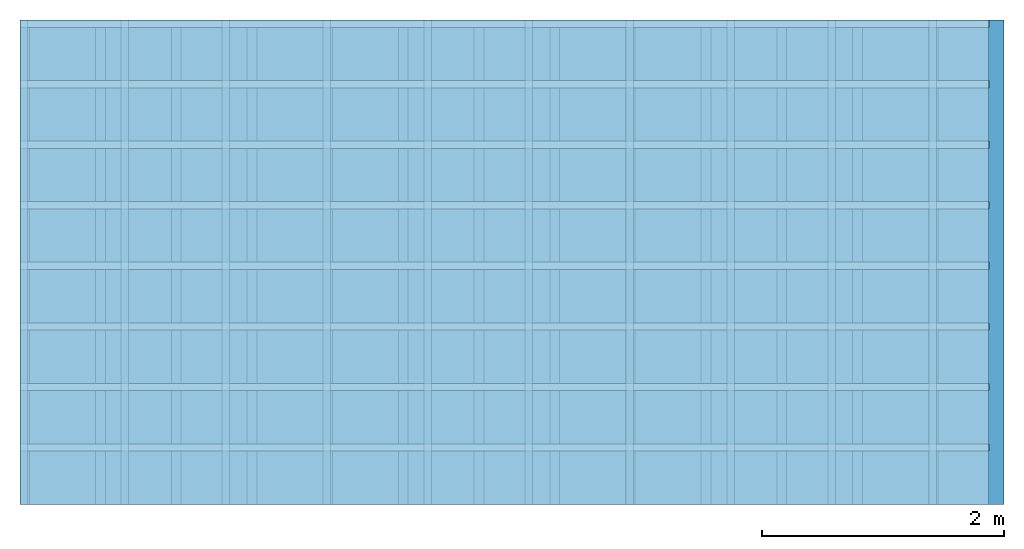
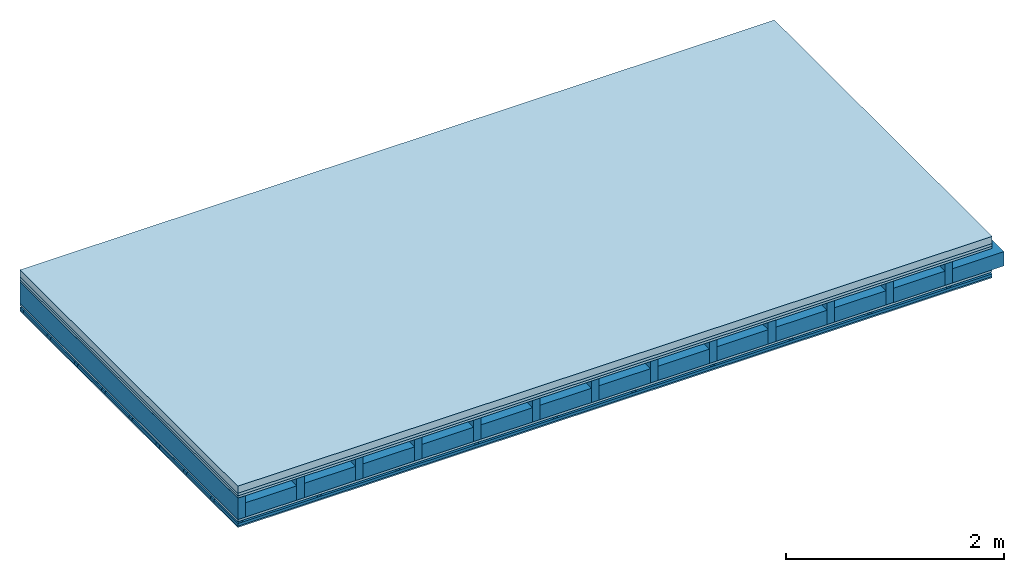
# One storey: 5 members, 5 plates, 1 element without a shape of its own.
"""IFC4 building model written with IfcOpenShell, lengths in metres."""

import ifcopenshell
import ifcopenshell.guid

model = None  # the IFC model being written
_history = None  # IfcOwnerHistory: only IFC2X3 demands one
_inside = {}  # id of a spatial element -> (the spatial element, [elements in it])
_under = {}  # id of a project, library or spatial element -> (it, [spatial elements below it])
_declared = {}  # id of a project -> (the project, [libraries it declares])
_typed = {}  # id of a type object -> (the type object, [elements of that type])
_made_of = {}  # id of a material, layer set ... -> (it, [elements and type objects made of it])


def new_model(schema):
    """Start an empty IFC model of exactly this schema.

    Asked for "IFC4X3", IfcOpenShell would pick the latest addendum, in which some entities
    have other attributes; the version numbers below select the first issue.
    IFC2X3 requires an IfcOwnerHistory on every rooted entity: one is made here for all.
    """
    global model, _history
    if schema == "IFC4X3":
        model = ifcopenshell.file(schema_version=(4, 3, 0, 0))
    else:
        model = ifcopenshell.file(schema=schema)
    _inside.clear()
    _under.clear()
    _declared.clear()
    _typed.clear()
    _made_of.clear()
    _history = None
    if model.schema == "IFC2X3":
        org = make("IfcOrganization", Name="unknown")
        user = make(
            "IfcPersonAndOrganization",
            ThePerson=make("IfcPerson", FamilyName="unknown"),
            TheOrganization=org,
        )
        app = make(
            "IfcApplication",
            ApplicationDeveloper=org,
            Version="unknown",
            ApplicationFullName="unknown",
            ApplicationIdentifier="unknown",
        )
        _history = make(
            "IfcOwnerHistory",
            OwningUser=user,
            OwningApplication=app,
            ChangeAction="ADDED",
            CreationDate=0,
        )
    return model


def make(cls, **values):
    """One entity of the class cls with the attributes given. An attribute that is None is left unset."""
    return model.create_entity(
        cls, **{name: value for name, value in values.items() if value is not None}
    )


def rooted(cls, **values):
    """An entity with a GlobalId (a new one), such as an element, a storey or a relation."""
    return make(cls, GlobalId=ifcopenshell.guid.new(), OwnerHistory=_history, **values)


def si_unit(unit_type, name, prefix=None):
    """IfcSIUnit, for example si_unit("LENGTHUNIT", "METRE", prefix="MILLI")."""
    return make("IfcSIUnit", UnitType=unit_type, Prefix=prefix, Name=name)


def derived_unit(unit_type, elements):
    """IfcDerivedUnit: a product of units, each with its exponent."""
    return make(
        "IfcDerivedUnit",
        Elements=[
            make("IfcDerivedUnitElement", Unit=unit, Exponent=power)
            for unit, power in elements
        ],
        UnitType=unit_type,
    )


def assignment(units):
    """IfcUnitAssignment: the units of a project."""
    return None if units is None else make("IfcUnitAssignment", Units=units)


def point(xyz):
    """IfcCartesianPoint."""
    return None if xyz is None else make("IfcCartesianPoint", Coordinates=xyz)


def direction(xyz):
    """IfcDirection."""
    return None if xyz is None else make("IfcDirection", DirectionRatios=xyz)


def frame(location, z_axis=None, x_axis=None):
    """IfcAxis2Placement3D, a coordinate frame: its origin and axes. An axis left out is left unset."""
    return make(
        "IfcAxis2Placement3D",
        Location=point(location),
        Axis=direction(z_axis),
        RefDirection=direction(x_axis),
    )


def frame_2d(location, x_axis=None):
    """IfcAxis2Placement2D, a coordinate frame in the plane: its origin and x axis."""
    return make(
        "IfcAxis2Placement2D", Location=point(location), RefDirection=direction(x_axis)
    )


def origin():
    """The frame at (0, 0, 0) with its axes left unset."""
    return frame((0.0, 0.0, 0.0))


def origin_with_axes():
    """The frame at (0, 0, 0) with the z axis (0, 0, 1) and the x axis (1, 0, 0) written out."""
    return frame((0.0, 0.0, 0.0), z_axis=(0.0, 0.0, 1.0), x_axis=(1.0, 0.0, 0.0))


def place(relative_to, where):
    """IfcLocalPlacement: puts the frame where relative to a parent placement (None: the world)."""
    return make(
        "IfcLocalPlacement", PlacementRelTo=relative_to, RelativePlacement=where
    )


def context(
    kind, dimensions, precision=None, world=None, true_north=None, identifier=None
):
    """IfcGeometricRepresentationContext, for example the 3D "Model" context."""
    return make(
        "IfcGeometricRepresentationContext",
        ContextIdentifier=identifier,
        ContextType=kind,
        CoordinateSpaceDimension=dimensions,
        Precision=precision,
        WorldCoordinateSystem=world,
        TrueNorth=true_north,
    )


def project(units=None, contexts=None):
    """IfcProject with its units and contexts."""
    return rooted(
        "IfcProject",
        Name="project",
        RepresentationContexts=contexts,
        UnitsInContext=assignment(units),
    )


def spatial(cls, under=None, at=None, **own):
    """A site, building, storey or space (cls), placed at a placement, below another one or the project."""
    s = rooted(cls, ObjectPlacement=at, **own)
    if under is not None:
        _under.setdefault(under.id(), (under, []))[1].append(s)
    return s


def polyline(points):
    """IfcPolyline through the points."""
    return make("IfcPolyline", Points=[point(p) for p in points])


def profile(cls, at=None, kind="AREA", **sizes):
    """A parametric profile (cls). Its sizes go by their IFC names, for example OverallWidth=200.0."""
    return make(cls, ProfileType=kind, Position=at, **sizes)


def rectangle(**sizes):
    """IfcRectangleProfileDef."""
    return profile("IfcRectangleProfileDef", **sizes)


def outline(outer, holes=None, kind="AREA"):
    """IfcArbitraryClosedProfileDef: a profile drawn as a closed curve; with holes, ...WithVoids."""
    if holes is None:
        return make("IfcArbitraryClosedProfileDef", ProfileType=kind, OuterCurve=outer)
    return make(
        "IfcArbitraryProfileDefWithVoids",
        ProfileType=kind,
        OuterCurve=outer,
        InnerCurves=holes,
    )


def extrude(swept, where, along, depth):
    """IfcExtrudedAreaSolid: the profile swept, set in the frame where, extruded along a direction by depth."""
    return make(
        "IfcExtrudedAreaSolid",
        SweptArea=swept,
        Position=where,
        ExtrudedDirection=direction(along),
        Depth=depth,
    )


def shape(context_of_items, identifier, shape_type, items):
    """IfcShapeRepresentation: the items that make up one representation, for example the "Body"."""
    return make(
        "IfcShapeRepresentation",
        ContextOfItems=context_of_items,
        RepresentationIdentifier=identifier,
        RepresentationType=shape_type,
        Items=items,
    )


def material(Name=None, Category=None):
    """IfcMaterial."""
    return make("IfcMaterial", Name=Name, Category=Category)


def layer(
    of_material, thickness, ventilated=None, Name=None, Category=None, Priority=None
):
    """IfcMaterialLayer: one layer of a wall or slab, of a material (None: an air gap)."""
    return make(
        "IfcMaterialLayer",
        Material=of_material,
        LayerThickness=thickness,
        IsVentilated=ventilated,
        Name=Name,
        Category=Category,
        Priority=Priority,
    )


def layer_set(layers, Name=None):
    """IfcMaterialLayerSet."""
    return make("IfcMaterialLayerSet", MaterialLayers=layers, LayerSetName=Name)


def made_of(thing, what):
    """Note that an element or type object is made of a material, layer set ...; save() writes the relation."""
    if what is not None:
        _made_of.setdefault(what.id(), (what, []))[1].append(thing)
    return thing


def type_object(cls, material=None, **own):
    """A type object (cls), such as IfcWallType, which elements share."""
    return made_of(rooted(cls, **own), material)


def element(
    cls,
    number,
    at=None,
    inside=None,
    cuts=None,
    type_object=None,
    material=None,
    context=None,
    identifier="Body",
    shape_type=None,
    held_by="IfcProductDefinitionShape",
    body=None,
    shapes=None,
    **own,
):
    """One element of the class cls, such as IfcWall. Its Tag is "e" and its number.

    at: its placement. inside: the storey or other place that contains it. cuts: it is an
    opening in that element (IfcRelVoidsElement). A single representation is given by context,
    identifier, shape_type and body (its items); several are given by shapes. held_by: the class
    of the entity that holds the representations. save() writes the other relations.
    """
    e = rooted(cls, Tag="e%d" % number, ObjectPlacement=at, **own)
    if body is not None:
        shapes = [shape(context, identifier, shape_type, body)]
    if shapes is not None:
        e.Representation = make(held_by, Representations=shapes)
    if inside is not None:
        _inside.setdefault(inside.id(), (inside, []))[1].append(e)
    if cuts is not None:
        rooted(
            "IfcRelVoidsElement", RelatingBuildingElement=cuts, RelatedOpeningElement=e
        )
    if type_object is not None:
        _typed.setdefault(type_object.id(), (type_object, []))[1].append(e)
    return made_of(e, material)


def aggregate(whole, parts):
    """IfcRelAggregates: a whole, such as a stair, and the parts it consists of."""
    return rooted("IfcRelAggregates", RelatingObject=whole, RelatedObjects=parts)


def save(model, path):
    """Write the relations noted so far, then the file.

    IfcRelAggregates (storeys below a building ...), IfcRelContainedInSpatialStructure (elements
    in a storey), IfcRelDefinesByType, IfcRelAssociatesMaterial and IfcRelDeclares: one each for
    every whole, place, type object, material and project.
    """
    for whole, parts in _under.values():
        aggregate(whole, parts)
    for where, things in _inside.values():
        rooted(
            "IfcRelContainedInSpatialStructure",
            RelatedElements=things,
            RelatingStructure=where,
        )
    for kind, things in _typed.values():
        rooted("IfcRelDefinesByType", RelatedObjects=things, RelatingType=kind)
    for what, things in _made_of.values():
        rooted("IfcRelAssociatesMaterial", RelatedObjects=things, RelatingMaterial=what)
    for by, libraries in _declared.values():
        rooted("IfcRelDeclares", RelatingContext=by, RelatedDefinitions=libraries)
    model.write(path)


model = new_model("IFC4")

# Units and contexts
plan_context = context("Plan", 3, precision=1e-05, world=origin(), true_north=direction((0.0, 1.0)))
model_context = context("Model", 3, precision=1e-05, world=origin(), true_north=direction((0.0, 1.0)))
ifc_project = project(units=[si_unit("LENGTHUNIT", "METRE"), derived_unit("SOUNDPRESSUREUNIT", [(si_unit("PRESSUREUNIT", "PASCAL", prefix="MICRO"), 0)]), si_unit("ENERGYUNIT", "JOULE", prefix="MEGA"), si_unit("MASSUNIT", "GRAM", prefix="KILO"), derived_unit("THERMALTRANSMITTANCEUNIT", [(si_unit("POWERUNIT", "WATT"), 1), (si_unit("AREAUNIT", "SQUARE_METRE"), -1), (si_unit("THERMODYNAMICTEMPERATUREUNIT", "KELVIN"), -1)]), derived_unit("AREADENSITYUNIT", [(si_unit("MASSUNIT", "GRAM", prefix="KILO"), 1), (si_unit("AREAUNIT", "SQUARE_METRE"), -1)]), derived_unit("USERDEFINED", [(si_unit("ENERGYUNIT", "JOULE", prefix="MEGA"), 1), (si_unit("AREAUNIT", "SQUARE_METRE"), -1)])], contexts=[plan_context, model_context])

# Site, building, storey
site = spatial("IfcSite", under=ifc_project)
building_placement = place(None, origin())
building = spatial("IfcBuilding", under=site, at=building_placement)
storey_placement = place(building_placement, origin())
storey = spatial("IfcBuildingStorey", under=building, at=storey_placement)

# Slab, members, plates
ifc_material_1 = material(Name="Cement screed", Category="04.006")
ifc_layer_1 = layer(ifc_material_1, 0.08, Name="On-material")
ifc_material_2 = material()
ifc_layer_2 = layer(ifc_material_2, 0.03, Name="Impact sound insulation")
ifc_material_3 = material(Category="07.001")
ifc_layer_3 = layer(ifc_material_3, 0.025, Name="Sub-floor")
ifc_material_4 = material(Name="Rigid, of the art")
ifc_layer_4 = layer(ifc_material_4, 0.0, Name="Bond")
ifc_layer_5 = layer(None, 0.24, Name="Supporting structure")
ifc_layer_6 = layer(ifc_material_4, 0.0, Name="Bond")
ifc_layer_7 = layer(ifc_material_3, 0.025, Name="Lower layer 1")
ifc_layer_8 = layer(None, 0.02, Name="Coupling")
ifc_layer_9 = layer(None, 0.03, Name="Battens / profiles")
ifc_material_5 = material(Category="03.007")
ifc_layer_10 = layer(ifc_material_5, 0.015, Name="Ceiling covering 1st layer")
ifc_material_6 = material(Name="Glued joints")
ifc_layer_11 = layer(ifc_material_6, 0.0, Name="Surface / treatment")
ifc_layer_set = layer_set([ifc_layer_1, ifc_layer_2, ifc_layer_3, ifc_layer_4, ifc_layer_5, ifc_layer_6, ifc_layer_7, ifc_layer_8, ifc_layer_9, ifc_layer_10, ifc_layer_11])
slab_type = type_object("IfcSlabType", Name="A0318", PredefinedType="NOTDEFINED", material=ifc_layer_set)
slab_placement = place(None, frame((0.0, 0.0, 0.0), z_axis=(0.0, 0.0, -1.0), x_axis=(1.0, 0.0, 0.0)))
slab = element("IfcSlab", 1, at=slab_placement, inside=storey, type_object=slab_type, material=ifc_layer_set, Name="Slab #1")
ifc_material_7 = material()
member_1_placement = place(slab_placement, origin())
member_1 = element("IfcMember", 2, at=member_1_placement, material=ifc_material_7, Name="Supporting structure", context=plan_context, shape_type="SweptSolid", body=[
    extrude(rectangle(XDim=0.08, YDim=0.24, at=frame_2d((0.04, 0.12), x_axis=(1.0, 0.0))), frame((0.0, 4.0, 0.135), z_axis=(0.0, -1.0, 0.0), x_axis=(1.0, 0.0, 0.0)), (0.0, 0.0, 1.0), 4.0),
    extrude(rectangle(XDim=0.08, YDim=0.24, at=frame_2d((0.04, 0.12), x_axis=(1.0, 0.0))), frame((0.625, 4.0, 0.135), z_axis=(0.0, -1.0, 0.0), x_axis=(1.0, 0.0, 0.0)), (0.0, 0.0, 1.0), 4.0),
    extrude(rectangle(XDim=0.08, YDim=0.24, at=frame_2d((0.04, 0.12), x_axis=(1.0, 0.0))), frame((1.25, 4.0, 0.135), z_axis=(0.0, -1.0, 0.0), x_axis=(1.0, 0.0, 0.0)), (0.0, 0.0, 1.0), 4.0),
    extrude(rectangle(XDim=0.08, YDim=0.24, at=frame_2d((0.04, 0.12), x_axis=(1.0, 0.0))), frame((1.875, 4.0, 0.135), z_axis=(0.0, -1.0, 0.0), x_axis=(1.0, 0.0, 0.0)), (0.0, 0.0, 1.0), 4.0),
    extrude(rectangle(XDim=0.08, YDim=0.24, at=frame_2d((0.04, 0.12), x_axis=(1.0, 0.0))), frame((2.5, 4.0, 0.135), z_axis=(0.0, -1.0, 0.0), x_axis=(1.0, 0.0, 0.0)), (0.0, 0.0, 1.0), 4.0),
    extrude(rectangle(XDim=0.08, YDim=0.24, at=frame_2d((0.04, 0.12), x_axis=(1.0, 0.0))), frame((3.125, 4.0, 0.135), z_axis=(0.0, -1.0, 0.0), x_axis=(1.0, 0.0, 0.0)), (0.0, 0.0, 1.0), 4.0),
    extrude(rectangle(XDim=0.08, YDim=0.24, at=frame_2d((0.04, 0.12), x_axis=(1.0, 0.0))), frame((3.75, 4.0, 0.135), z_axis=(0.0, -1.0, 0.0), x_axis=(1.0, 0.0, 0.0)), (0.0, 0.0, 1.0), 4.0),
    extrude(rectangle(XDim=0.08, YDim=0.24, at=frame_2d((0.04, 0.12), x_axis=(1.0, 0.0))), frame((4.375, 4.0, 0.135), z_axis=(0.0, -1.0, 0.0), x_axis=(1.0, 0.0, 0.0)), (0.0, 0.0, 1.0), 4.0),
    extrude(rectangle(XDim=0.08, YDim=0.24, at=frame_2d((0.04, 0.12), x_axis=(1.0, 0.0))), frame((5.0, 4.0, 0.135), z_axis=(0.0, -1.0, 0.0), x_axis=(1.0, 0.0, 0.0)), (0.0, 0.0, 1.0), 4.0),
    extrude(rectangle(XDim=0.08, YDim=0.24, at=frame_2d((0.04, 0.12), x_axis=(1.0, 0.0))), frame((5.625, 4.0, 0.135), z_axis=(0.0, -1.0, 0.0), x_axis=(1.0, 0.0, 0.0)), (0.0, 0.0, 1.0), 4.0),
    extrude(rectangle(XDim=0.08, YDim=0.24, at=frame_2d((0.04, 0.12), x_axis=(1.0, 0.0))), frame((6.25, 4.0, 0.135), z_axis=(0.0, -1.0, 0.0), x_axis=(1.0, 0.0, 0.0)), (0.0, 0.0, 1.0), 4.0),
    extrude(rectangle(XDim=0.08, YDim=0.24, at=frame_2d((0.04, 0.12), x_axis=(1.0, 0.0))), frame((6.875, 4.0, 0.135), z_axis=(0.0, -1.0, 0.0), x_axis=(1.0, 0.0, 0.0)), (0.0, 0.0, 1.0), 4.0),
    extrude(rectangle(XDim=0.08, YDim=0.24, at=frame_2d((0.04, 0.12), x_axis=(1.0, 0.0))), frame((7.5, 4.0, 0.135), z_axis=(0.0, -1.0, 0.0), x_axis=(1.0, 0.0, 0.0)), (0.0, 0.0, 1.0), 4.0),
])
ifc_material_8 = material()
member_2_placement = place(slab_placement, origin())
member_2 = element("IfcMember", 3, at=member_2_placement, material=ifc_material_8, Name="Cavity", context=plan_context, shape_type="SweptSolid", body=[
    extrude(rectangle(XDim=0.545, YDim=0.16, at=frame_2d((0.2725, 0.08), x_axis=(1.0, 0.0))), frame((0.08, 4.0, 0.215), z_axis=(0.0, -1.0, 0.0), x_axis=(1.0, 0.0, 0.0)), (0.0, 0.0, 1.0), 4.0),
    extrude(rectangle(XDim=0.545, YDim=0.16, at=frame_2d((0.2725, 0.08), x_axis=(1.0, 0.0))), frame((0.705, 4.0, 0.215), z_axis=(0.0, -1.0, 0.0), x_axis=(1.0, 0.0, 0.0)), (0.0, 0.0, 1.0), 4.0),
    extrude(rectangle(XDim=0.545, YDim=0.16, at=frame_2d((0.2725, 0.08), x_axis=(1.0, 0.0))), frame((1.33, 4.0, 0.215), z_axis=(0.0, -1.0, 0.0), x_axis=(1.0, 0.0, 0.0)), (0.0, 0.0, 1.0), 4.0),
    extrude(rectangle(XDim=0.545, YDim=0.16, at=frame_2d((0.2725, 0.08), x_axis=(1.0, 0.0))), frame((1.955, 4.0, 0.215), z_axis=(0.0, -1.0, 0.0), x_axis=(1.0, 0.0, 0.0)), (0.0, 0.0, 1.0), 4.0),
    extrude(rectangle(XDim=0.545, YDim=0.16, at=frame_2d((0.2725, 0.08), x_axis=(1.0, 0.0))), frame((2.58, 4.0, 0.215), z_axis=(0.0, -1.0, 0.0), x_axis=(1.0, 0.0, 0.0)), (0.0, 0.0, 1.0), 4.0),
    extrude(rectangle(XDim=0.545, YDim=0.16, at=frame_2d((0.2725, 0.08), x_axis=(1.0, 0.0))), frame((3.205, 4.0, 0.215), z_axis=(0.0, -1.0, 0.0), x_axis=(1.0, 0.0, 0.0)), (0.0, 0.0, 1.0), 4.0),
    extrude(rectangle(XDim=0.545, YDim=0.16, at=frame_2d((0.2725, 0.08), x_axis=(1.0, 0.0))), frame((3.83, 4.0, 0.215), z_axis=(0.0, -1.0, 0.0), x_axis=(1.0, 0.0, 0.0)), (0.0, 0.0, 1.0), 4.0),
    extrude(rectangle(XDim=0.545, YDim=0.16, at=frame_2d((0.2725, 0.08), x_axis=(1.0, 0.0))), frame((4.455, 4.0, 0.215), z_axis=(0.0, -1.0, 0.0), x_axis=(1.0, 0.0, 0.0)), (0.0, 0.0, 1.0), 4.0),
    extrude(rectangle(XDim=0.545, YDim=0.16, at=frame_2d((0.2725, 0.08), x_axis=(1.0, 0.0))), frame((5.08, 4.0, 0.215), z_axis=(0.0, -1.0, 0.0), x_axis=(1.0, 0.0, 0.0)), (0.0, 0.0, 1.0), 4.0),
    extrude(rectangle(XDim=0.545, YDim=0.16, at=frame_2d((0.2725, 0.08), x_axis=(1.0, 0.0))), frame((5.705, 4.0, 0.215), z_axis=(0.0, -1.0, 0.0), x_axis=(1.0, 0.0, 0.0)), (0.0, 0.0, 1.0), 4.0),
    extrude(rectangle(XDim=0.545, YDim=0.16, at=frame_2d((0.2725, 0.08), x_axis=(1.0, 0.0))), frame((6.33, 4.0, 0.215), z_axis=(0.0, -1.0, 0.0), x_axis=(1.0, 0.0, 0.0)), (0.0, 0.0, 1.0), 4.0),
    extrude(rectangle(XDim=0.545, YDim=0.16, at=frame_2d((0.2725, 0.08), x_axis=(1.0, 0.0))), frame((6.955, 4.0, 0.215), z_axis=(0.0, -1.0, 0.0), x_axis=(1.0, 0.0, 0.0)), (0.0, 0.0, 1.0), 4.0),
    extrude(rectangle(XDim=0.545, YDim=0.16, at=frame_2d((0.2725, 0.08), x_axis=(1.0, 0.0))), frame((7.58, 4.0, 0.215), z_axis=(0.0, -1.0, 0.0), x_axis=(1.0, 0.0, 0.0)), (0.0, 0.0, 1.0), 4.0),
])
ifc_material_9 = material()
member_3_placement = place(slab_placement, origin())
member_3 = element("IfcMember", 4, at=member_3_placement, material=ifc_material_9, Name="Coupling", context=plan_context, shape_type="SweptSolid", body=[
    extrude(outline(polyline([(0.0, 0.0), (0.06, 0.0), (0.04, 0.02), (0.02, 0.02), (0.0, 0.0)])), frame((0.0, 4.0, 0.4), z_axis=(0.0, -1.0, 0.0), x_axis=(1.0, 0.0, 0.0)), (0.0, 0.0, 1.0), 4.0),
    extrude(outline(polyline([(0.0, 0.0), (0.06, 0.0), (0.04, 0.02), (0.02, 0.02), (0.0, 0.0)])), frame((0.834, 4.0, 0.4), z_axis=(0.0, -1.0, 0.0), x_axis=(1.0, 0.0, 0.0)), (0.0, 0.0, 1.0), 4.0),
    extrude(outline(polyline([(0.0, 0.0), (0.06, 0.0), (0.04, 0.02), (0.02, 0.02), (0.0, 0.0)])), frame((1.668, 4.0, 0.4), z_axis=(0.0, -1.0, 0.0), x_axis=(1.0, 0.0, 0.0)), (0.0, 0.0, 1.0), 4.0),
    extrude(outline(polyline([(0.0, 0.0), (0.06, 0.0), (0.04, 0.02), (0.02, 0.02), (0.0, 0.0)])), frame((2.502, 4.0, 0.4), z_axis=(0.0, -1.0, 0.0), x_axis=(1.0, 0.0, 0.0)), (0.0, 0.0, 1.0), 4.0),
    extrude(outline(polyline([(0.0, 0.0), (0.06, 0.0), (0.04, 0.02), (0.02, 0.02), (0.0, 0.0)])), frame((3.336, 4.0, 0.4), z_axis=(0.0, -1.0, 0.0), x_axis=(1.0, 0.0, 0.0)), (0.0, 0.0, 1.0), 4.0),
    extrude(outline(polyline([(0.0, 0.0), (0.06, 0.0), (0.04, 0.02), (0.02, 0.02), (0.0, 0.0)])), frame((4.17, 4.0, 0.4), z_axis=(0.0, -1.0, 0.0), x_axis=(1.0, 0.0, 0.0)), (0.0, 0.0, 1.0), 4.0),
    extrude(outline(polyline([(0.0, 0.0), (0.06, 0.0), (0.04, 0.02), (0.02, 0.02), (0.0, 0.0)])), frame((5.004, 4.0, 0.4), z_axis=(0.0, -1.0, 0.0), x_axis=(1.0, 0.0, 0.0)), (0.0, 0.0, 1.0), 4.0),
    extrude(outline(polyline([(0.0, 0.0), (0.06, 0.0), (0.04, 0.02), (0.02, 0.02), (0.0, 0.0)])), frame((5.838, 4.0, 0.4), z_axis=(0.0, -1.0, 0.0), x_axis=(1.0, 0.0, 0.0)), (0.0, 0.0, 1.0), 4.0),
    extrude(outline(polyline([(0.0, 0.0), (0.06, 0.0), (0.04, 0.02), (0.02, 0.02), (0.0, 0.0)])), frame((6.672, 4.0, 0.4), z_axis=(0.0, -1.0, 0.0), x_axis=(1.0, 0.0, 0.0)), (0.0, 0.0, 1.0), 4.0),
    extrude(outline(polyline([(0.0, 0.0), (0.06, 0.0), (0.04, 0.02), (0.02, 0.02), (0.0, 0.0)])), frame((7.506, 4.0, 0.4), z_axis=(0.0, -1.0, 0.0), x_axis=(1.0, 0.0, 0.0)), (0.0, 0.0, 1.0), 4.0),
])
ifc_material_10 = material()
member_4_placement = place(slab_placement, origin())
member_4 = element("IfcMember", 5, at=member_4_placement, material=ifc_material_10, Name="Battens / profiles", context=plan_context, shape_type="SweptSolid", body=[
    extrude(rectangle(XDim=0.06, YDim=0.03, at=frame_2d((0.03, 0.015), x_axis=(1.0, 0.0))), frame((0.0, 0.0, 0.42), z_axis=(1.0, 0.0, 0.0), x_axis=(0.0, 1.0, 0.0)), (0.0, 0.0, 1.0), 8.0),
    extrude(rectangle(XDim=0.06, YDim=0.03, at=frame_2d((0.03, 0.015), x_axis=(1.0, 0.0))), frame((0.0, 0.5, 0.42), z_axis=(1.0, 0.0, 0.0), x_axis=(0.0, 1.0, 0.0)), (0.0, 0.0, 1.0), 8.0),
    extrude(rectangle(XDim=0.06, YDim=0.03, at=frame_2d((0.03, 0.015), x_axis=(1.0, 0.0))), frame((0.0, 1.0, 0.42), z_axis=(1.0, 0.0, 0.0), x_axis=(0.0, 1.0, 0.0)), (0.0, 0.0, 1.0), 8.0),
    extrude(rectangle(XDim=0.06, YDim=0.03, at=frame_2d((0.03, 0.015), x_axis=(1.0, 0.0))), frame((0.0, 1.5, 0.42), z_axis=(1.0, 0.0, 0.0), x_axis=(0.0, 1.0, 0.0)), (0.0, 0.0, 1.0), 8.0),
    extrude(rectangle(XDim=0.06, YDim=0.03, at=frame_2d((0.03, 0.015), x_axis=(1.0, 0.0))), frame((0.0, 2.0, 0.42), z_axis=(1.0, 0.0, 0.0), x_axis=(0.0, 1.0, 0.0)), (0.0, 0.0, 1.0), 8.0),
    extrude(rectangle(XDim=0.06, YDim=0.03, at=frame_2d((0.03, 0.015), x_axis=(1.0, 0.0))), frame((0.0, 2.5, 0.42), z_axis=(1.0, 0.0, 0.0), x_axis=(0.0, 1.0, 0.0)), (0.0, 0.0, 1.0), 8.0),
    extrude(rectangle(XDim=0.06, YDim=0.03, at=frame_2d((0.03, 0.015), x_axis=(1.0, 0.0))), frame((0.0, 3.0, 0.42), z_axis=(1.0, 0.0, 0.0), x_axis=(0.0, 1.0, 0.0)), (0.0, 0.0, 1.0), 8.0),
    extrude(rectangle(XDim=0.06, YDim=0.03, at=frame_2d((0.03, 0.015), x_axis=(1.0, 0.0))), frame((0.0, 3.5, 0.42), z_axis=(1.0, 0.0, 0.0), x_axis=(0.0, 1.0, 0.0)), (0.0, 0.0, 1.0), 8.0),
])
member_5_placement = place(slab_placement, origin())
member_5 = element("IfcMember", 6, at=member_5_placement, material=ifc_material_8, Name="Cavity", context=plan_context, shape_type="SweptSolid", body=[
    extrude(rectangle(XDim=0.44, YDim=0.03, at=frame_2d((0.22, 0.015), x_axis=(1.0, 0.0))), frame((0.0, 0.06, 0.42), z_axis=(1.0, 0.0, 0.0), x_axis=(0.0, 1.0, 0.0)), (0.0, 0.0, 1.0), 8.0),
    extrude(rectangle(XDim=0.44, YDim=0.03, at=frame_2d((0.22, 0.015), x_axis=(1.0, 0.0))), frame((0.0, 0.56, 0.42), z_axis=(1.0, 0.0, 0.0), x_axis=(0.0, 1.0, 0.0)), (0.0, 0.0, 1.0), 8.0),
    extrude(rectangle(XDim=0.44, YDim=0.03, at=frame_2d((0.22, 0.015), x_axis=(1.0, 0.0))), frame((0.0, 1.06, 0.42), z_axis=(1.0, 0.0, 0.0), x_axis=(0.0, 1.0, 0.0)), (0.0, 0.0, 1.0), 8.0),
    extrude(rectangle(XDim=0.44, YDim=0.03, at=frame_2d((0.22, 0.015), x_axis=(1.0, 0.0))), frame((0.0, 1.56, 0.42), z_axis=(1.0, 0.0, 0.0), x_axis=(0.0, 1.0, 0.0)), (0.0, 0.0, 1.0), 8.0),
    extrude(rectangle(XDim=0.44, YDim=0.03, at=frame_2d((0.22, 0.015), x_axis=(1.0, 0.0))), frame((0.0, 2.06, 0.42), z_axis=(1.0, 0.0, 0.0), x_axis=(0.0, 1.0, 0.0)), (0.0, 0.0, 1.0), 8.0),
    extrude(rectangle(XDim=0.44, YDim=0.03, at=frame_2d((0.22, 0.015), x_axis=(1.0, 0.0))), frame((0.0, 2.56, 0.42), z_axis=(1.0, 0.0, 0.0), x_axis=(0.0, 1.0, 0.0)), (0.0, 0.0, 1.0), 8.0),
    extrude(rectangle(XDim=0.44, YDim=0.03, at=frame_2d((0.22, 0.015), x_axis=(1.0, 0.0))), frame((0.0, 3.06, 0.42), z_axis=(1.0, 0.0, 0.0), x_axis=(0.0, 1.0, 0.0)), (0.0, 0.0, 1.0), 8.0),
    extrude(rectangle(XDim=0.44, YDim=0.03, at=frame_2d((0.22, 0.015), x_axis=(1.0, 0.0))), frame((0.0, 3.56, 0.42), z_axis=(1.0, 0.0, 0.0), x_axis=(0.0, 1.0, 0.0)), (0.0, 0.0, 1.0), 8.0),
])
plate_1_placement = place(slab_placement, origin())
plate_1 = element("IfcPlate", 7, at=plate_1_placement, material=ifc_material_1, Name="On-material", context=plan_context, shape_type="SweptSolid", body=[
    extrude(rectangle(XDim=8.0, YDim=4.0, at=frame_2d((4.0, 2.0), x_axis=(1.0, 0.0))), origin_with_axes(), (0.0, 0.0, 1.0), 0.08),
])
plate_2_placement = place(slab_placement, origin())
plate_2 = element("IfcPlate", 8, at=plate_2_placement, material=ifc_material_2, Name="Impact sound insulation", context=plan_context, shape_type="SweptSolid", body=[
    extrude(rectangle(XDim=8.0, YDim=4.0, at=frame_2d((4.0, 2.0), x_axis=(1.0, 0.0))), frame((0.0, 0.0, 0.08), z_axis=(0.0, 0.0, 1.0), x_axis=(1.0, 0.0, 0.0)), (0.0, 0.0, 1.0), 0.03),
])
plate_3_placement = place(slab_placement, origin())
plate_3 = element("IfcPlate", 9, at=plate_3_placement, material=ifc_material_3, Name="Sub-floor", context=plan_context, shape_type="SweptSolid", body=[
    extrude(rectangle(XDim=8.0, YDim=4.0, at=frame_2d((4.0, 2.0), x_axis=(1.0, 0.0))), frame((0.0, 0.0, 0.11), z_axis=(0.0, 0.0, 1.0), x_axis=(1.0, 0.0, 0.0)), (0.0, 0.0, 1.0), 0.025),
])
plate_4_placement = place(slab_placement, origin())
plate_4 = element("IfcPlate", 10, at=plate_4_placement, material=ifc_material_3, Name="Lower layer 1", context=plan_context, shape_type="SweptSolid", body=[
    extrude(rectangle(XDim=8.0, YDim=4.0, at=frame_2d((4.0, 2.0), x_axis=(1.0, 0.0))), frame((0.0, 0.0, 0.375), z_axis=(0.0, 0.0, 1.0), x_axis=(1.0, 0.0, 0.0)), (0.0, 0.0, 1.0), 0.025),
])
plate_5_placement = place(slab_placement, origin())
plate_5 = element("IfcPlate", 11, at=plate_5_placement, material=ifc_material_5, Name="Ceiling covering 1st layer", context=plan_context, shape_type="SweptSolid", body=[
    extrude(rectangle(XDim=8.0, YDim=4.0, at=frame_2d((4.0, 2.0), x_axis=(1.0, 0.0))), frame((0.0, 0.0, 0.45), z_axis=(0.0, 0.0, 1.0), x_axis=(1.0, 0.0, 0.0)), (0.0, 0.0, 1.0), 0.015),
])
aggregate(slab, [plate_1, plate_2, plate_3, member_1, member_2, plate_4, member_3, member_4, member_5, plate_5])

save(model, "model.ifc")
